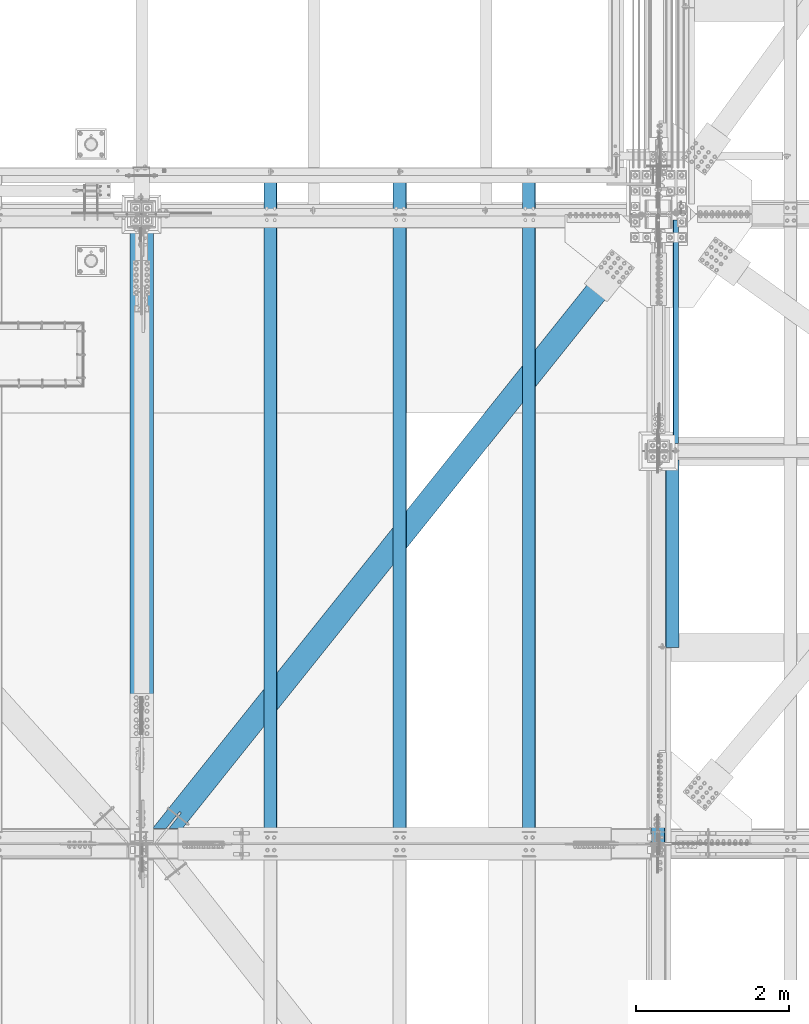
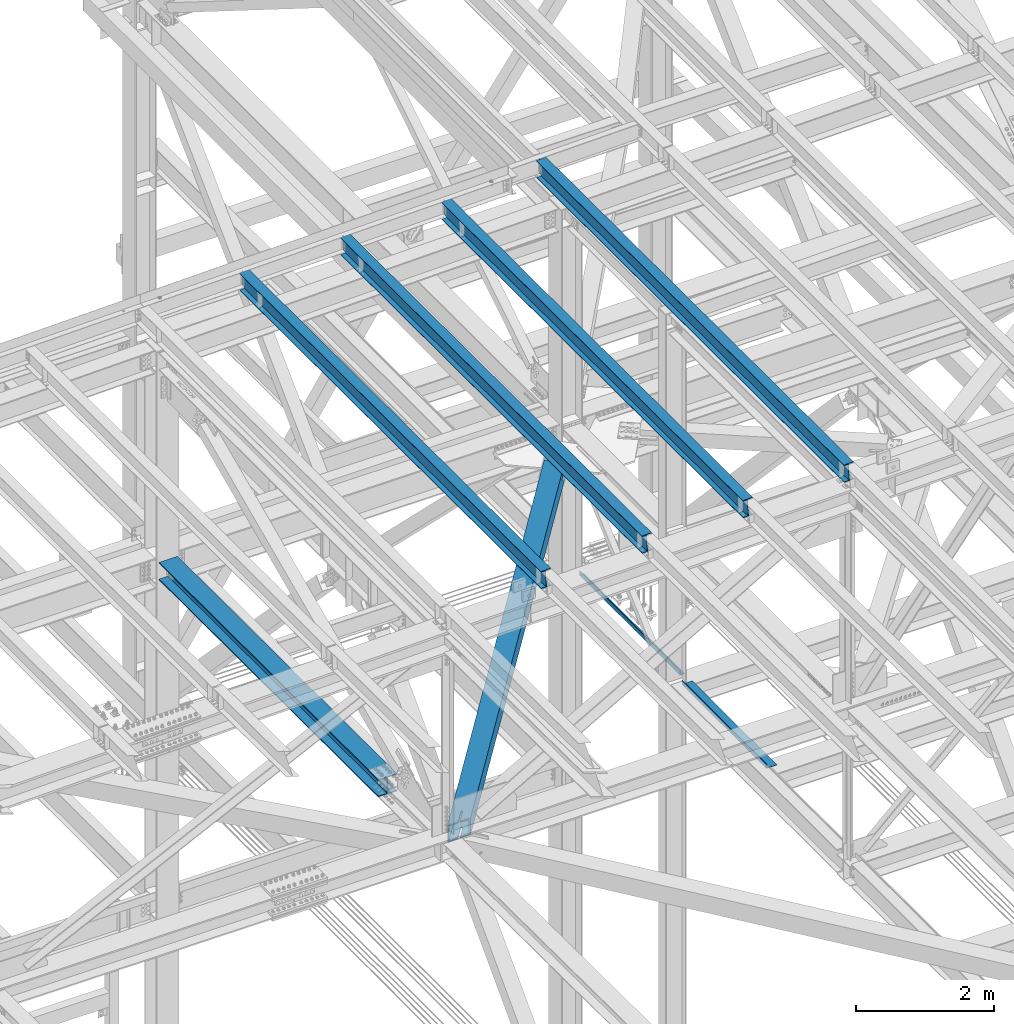
# One storey, part 1929 of 3843: 8 beams, 8 elements without a shape of their own.
"""IFC2X3 building model written with IfcOpenShell, lengths in millimetres."""

from ifc_helpers import new_model, si_unit, frame, origin_with_axes, place, context, subcontext, project, spatial, faceted_brep, material, type_object, element, aggregate, save


model = new_model("IFC2X3")

# Units and contexts
model_context = context("Model", 3, precision=1e-05, world=origin_with_axes())
body_context = subcontext(model_context, "Body", "Model", "MODEL_VIEW")
ifc_project = project(units=[si_unit("LENGTHUNIT", "METRE", prefix="MILLI"), si_unit("AREAUNIT", "SQUARE_METRE"), si_unit("VOLUMEUNIT", "CUBIC_METRE"), si_unit("MASSUNIT", "GRAM", prefix="KILO"), si_unit("TIMEUNIT", "SECOND"), si_unit("PLANEANGLEUNIT", "RADIAN"), si_unit("SOLIDANGLEUNIT", "STERADIAN"), si_unit("THERMODYNAMICTEMPERATUREUNIT", "DEGREE_CELSIUS"), si_unit("LUMINOUSINTENSITYUNIT", "LUMEN")], contexts=[model_context])

# Site, building, storey
site_placement = place(None, origin_with_axes())
site = spatial("IfcSite", under=ifc_project, at=site_placement, CompositionType="ELEMENT")
building_placement = place(site_placement, origin_with_axes())
building = spatial("IfcBuilding", under=site, at=building_placement, Name="Undefined", CompositionType="ELEMENT")
storey_placement = place(building_placement, origin_with_axes())
storey = spatial("IfcBuildingStorey", under=building, at=storey_placement, Name="Undefined", CompositionType="ELEMENT", Elevation=0.0)

# Assembly, beam
assembly_1_placement = place(storey_placement, origin_with_axes())
assembly_1 = element("IfcElementAssembly", 1, at=assembly_1_placement, inside=storey, Name="BEAM", AssemblyPlace="NOTDEFINED", PredefinedType="RIGID_FRAME")
ifc_material_1 = material(Name="STEEL/A992")
beam_type_1 = type_object("IfcBeamType", Name="W12X26", PredefinedType="NOTDEFINED")
beam_1_placement = place(assembly_1_placement, frame((75320.4092623347, 83985.4146285505, 46411.5735238448), z_axis=(-0.021152098282546, 0.00202235899982043, 0.99977422391374), x_axis=(0.0, 0.999997954113713, -0.00202281200022976)))
beam_1 = element("IfcBeam", 2, at=beam_1_placement, type_object=beam_type_1, material=ifc_material_1, Name="BEAM", ObjectType="W12X26", context=body_context, shape_type="Brep", body=[
    faceted_brep([(8748.73407185475, -3.1749999998865, -146.049999975927), (8748.73407185473, -82.5500000003231, -146.049999975927), (8748.73407185476, -82.5500000002648, -155.57499997595), (8748.73407185478, 82.5500000006286, -155.57499997595), (8748.73407185476, 82.550000000585, -146.049999975934), (8748.73407185475, 3.17500000014843, -146.049999975927), (8748.7340718543, 3.17500000013388, -142.874999314576), (8748.73407185433, -3.1749999998865, -142.874999314554), (8749.70080177688, 3.17500000011933, -138.014919796507), (8749.70080177693, -3.1749999999156, -138.014919796478), (8752.45381567739, 3.17500000011933, -133.894743328317), (8752.45381567742, -3.17499999993015, -133.894743328288), (8756.5739921456, 3.17500000009022, -131.141729427814), (8756.5739921456, -3.17499999993015, -131.141729427778), (8761.43407166368, 3.17500000007567, -130.174999505201), (8761.43407166369, -3.1749999999447, -130.174999505172), (8818.52903538667, -3.17499999995925, -130.174999504052), (8818.52930708288, 3.17500000009022, -130.174999504023), (12.090166436974, 3.17499999934807, 146.050000000345), (12.0935626394639, 82.5499999997701, 146.050000000352), (8748.73407185427, 82.5499999992608, 146.050000024705), (8748.73407185427, 3.17499999882421, 146.050000024705), (12.6964939507743, -82.5499999997555, -155.575000000295), (12.6772309377411, -82.5499999997992, -146.050000000272), (12.6806271402311, -3.17499999937718, -146.050000000272), (12.0898947407695, -3.1750000007014, 146.050000000352), (12.0864985383087, -82.5500000011234, 146.050000000359), (12.0672355252755, -82.5500000011816, 155.575000000375), (12.0742996264307, 82.5499999997264, 155.575000000368), (12.6808988364355, 3.1750000006723, -146.050000000272), (12.6842950389109, 82.5500000010943, -146.050000000272), (12.7035580519441, 82.5500000011525, -155.575000000295), (8748.73407185425, -3.17500000121072, 146.050000024705), (8748.73407185425, -82.5500000016327, 146.050000024705), (8748.73407185423, -82.5500000016909, 155.575000024728), (8748.73407185423, 82.5499999992171, 155.575000024721), (8748.73407185383, -3.17500000121072, 142.875000305459), (8748.73407185382, 3.17499999882421, 142.87500030543), (8749.70080177645, -3.17500000118162, 138.014920787384), (8749.7008017764, 3.17499999886786, 138.014920787355), (8752.45381567696, -3.17500000115251, 133.894744319208), (8752.45381567693, 3.17499999888241, 133.894744319179), (8756.57399214516, -3.17500000115251, 131.141730418734), (8756.57399214513, 3.17499999889696, 131.141730418698), (8761.43407166327, -3.17500000115251, 130.175000496143), (8761.43407166324, 3.17499999888241, 130.175000496121), (8818.00251303065, -3.17500000113796, 130.175000497125), (8818.00278472685, 3.17499999889696, 130.175000497155), (8818.49469513241, 3.17500000000291, -113.06039610249), (8818.02833904634, 3.17499999895517, 117.539132327023)], [[[0, 1, 2, 3, 4, 5, 6, 7]], [[7, 6, 8, 9]], [[9, 8, 10, 11]], [[11, 10, 12, 13]], [[13, 12, 14, 15]], [[16, 15, 14, 17]], [[18, 19, 20, 21]], [[22, 23, 24, 25, 26, 27, 28, 19, 18, 29, 30, 31]], [[26, 25, 32, 33]], [[27, 26, 33, 34]], [[28, 27, 34, 35]], [[19, 28, 35, 20]], [[34, 33, 32, 36, 37, 21, 20, 35]], [[38, 39, 37, 36]], [[40, 41, 39, 38]], [[42, 43, 41, 40]], [[44, 45, 43, 42]], [[46, 47, 45, 44]], [[48, 49, 47, 46, 16, 17]], [[12, 10, 8, 6, 5, 29, 18, 21, 37, 39, 41, 43, 45, 47, 49, 48, 17, 14]], [[30, 29, 5, 4]], [[31, 30, 4, 3]], [[22, 31, 3, 2]], [[23, 22, 2, 1]], [[24, 23, 1, 0]], [[46, 44, 42, 40, 38, 36, 32, 25, 24, 0, 7, 9, 11, 13, 15, 16]]]),
])
aggregate(assembly_1, [beam_1])

assembly_2_placement = place(storey_placement, origin_with_axes())
assembly_2 = element("IfcElementAssembly", 3, at=assembly_2_placement, inside=storey, Name="BEAM", AssemblyPlace="NOTDEFINED", PredefinedType="RIGID_FRAME")
beam_2_placement = place(assembly_2_placement, frame((77009.5092627052, 83985.4379680159, 46448.9393835819), z_axis=(-0.021152097941289, 0.00217238000044017, 0.999773909200383), x_axis=(0.0, 0.999997639323885, -0.00217286600070357)))
beam_2 = element("IfcBeam", 4, at=beam_2_placement, type_object=beam_type_1, material=ifc_material_1, Name="BEAM", ObjectType="W12X26", context=body_context, shape_type="Brep", body=[
    faceted_brep([(8924.94998399743, -3.17500000086147, -146.049999988769), (8924.94998399742, -82.5500000013126, -146.049999988587), (8924.94998399743, -82.5500000013417, -155.574999988588), (8924.94998399743, 82.5499999995955, -155.574999988974), (8924.94998399742, 82.5499999996246, -146.049999988973), (8924.94998399742, 3.17499999917345, -146.049999988783), (8924.94998399605, 3.17499999920256, -142.874999508247), (8924.94998399614, -3.17500000084692, -142.87499950824), (8925.91671391873, 3.17499999921711, -138.014919990193), (8925.91671391881, -3.17500000081782, -138.014919990186), (8928.66972781932, 3.17499999923166, -133.894743522018), (8928.66972781942, -3.17500000080327, -133.894743522011), (8932.78990428759, 3.17499999924621, -131.141729621493), (8932.78990428768, -3.17500000078871, -131.1417296215), (8937.64998380574, 3.17499999924621, -130.174999698858), (8937.64998380582, -3.17500000078871, -130.174999698858), (8975.69115626781, 3.17499999923166, -130.174999697447), (8975.69086441689, -3.17500000078871, -130.174999697425), (12.0449302655761, 3.17500000062864, 146.050000000061), (12.048578402173, 82.5500000010652, 146.049999999879), (8924.94998399782, 82.5500000008324, 146.050000011121), (8924.94998399782, 3.17500000039581, 146.05000001131), (12.6962628250476, -82.5500000003522, -155.574999999924), (12.675543931924, -82.5500000010652, -146.049999999828), (12.6791920685064, -3.17500000061409, -146.050000000017), (12.0446384146489, -3.17499999942083, 146.050000000076), (12.0409902780666, -82.5499999998574, 146.050000000265), (12.0202983110794, -82.5499999998283, 155.575000000274), (12.0278864352003, 82.5500000010943, 155.574999999873), (12.6794839194336, 3.17499999940628, -146.050000000032), (12.6831320560304, 82.5499999998574, -146.050000000214), (12.7037963889888, 82.550000000585, -155.57500000039), (8924.94998399784, -3.17499999965366, 146.050000011324), (8924.94998399782, -82.5500000000902, 146.050000011513), (8924.94998399782, -82.5500000000611, 155.575000011515), (8924.94998399782, 82.5500000008615, 155.575000011129), (8924.94998399614, -3.17499999966822, 142.875000110747), (8924.94998399603, 3.17500000036671, 142.875000110747), (8925.91671391868, -3.17499999969732, 138.014920592701), (8925.91671391857, 3.1750000003376, 138.014920592701), (8928.66972781914, -3.17499999971187, 133.894744124562), (8928.66972781904, 3.1750000003376, 133.894744124569), (8932.78990428733, -3.17499999972642, 131.141730224117), (8932.78990428725, 3.17500000032305, 131.141730224117), (8937.64998380546, -3.17499999971187, 130.175000301584), (8937.64998380536, 3.1750000003085, 130.175000301577), (8975.12557583718, 3.1750000003085, 130.175000301024), (8975.12528398627, -3.17499999972642, 130.175000301046)], [[[0, 1, 2, 3, 4, 5, 6, 7]], [[7, 6, 8, 9]], [[9, 8, 10, 11]], [[11, 10, 12, 13]], [[13, 12, 14, 15]], [[16, 17, 15, 14]], [[18, 19, 20, 21]], [[22, 23, 24, 25, 26, 27, 28, 19, 18, 29, 30, 31]], [[26, 25, 32, 33]], [[27, 26, 33, 34]], [[28, 27, 34, 35]], [[19, 28, 35, 20]], [[34, 33, 32, 36, 37, 21, 20, 35]], [[38, 39, 37, 36]], [[40, 41, 39, 38]], [[42, 43, 41, 40]], [[44, 45, 43, 42]], [[46, 45, 44, 47]], [[12, 10, 8, 6, 5, 29, 18, 21, 37, 39, 41, 43, 45, 46, 16, 14]], [[30, 29, 5, 4]], [[31, 30, 4, 3]], [[22, 31, 3, 2]], [[23, 22, 2, 1]], [[24, 23, 1, 0]], [[47, 44, 42, 40, 38, 36, 32, 25, 24, 0, 7, 9, 11, 13, 15, 17]], [[46, 47, 17, 16]]]),
])
aggregate(assembly_2, [beam_2])

assembly_3_placement = place(storey_placement, origin_with_axes())
assembly_3 = element("IfcElementAssembly", 5, at=assembly_3_placement, inside=storey, Name="BEAM", AssemblyPlace="NOTDEFINED", PredefinedType="RIGID_FRAME")
beam_3_placement = place(assembly_3_placement, frame((73631.3092623541, 83985.4146285505, 46375.8375062073), z_axis=(-0.021152098282546, 0.00202235899982043, 0.99977422391374), x_axis=(0.0, 0.999997954113713, -0.00202281200022976)))
beam_3 = element("IfcBeam", 6, at=beam_3_placement, type_object=beam_type_1, material=ifc_material_1, Name="BEAM", ObjectType="W12X26", context=body_context, shape_type="Brep", body=[
    faceted_brep([(8748.73407185475, -3.1749999998865, -146.049999975927), (8748.73407185473, -82.5500000003231, -146.049999975927), (8748.73407185476, -82.5500000002648, -155.57499997595), (8748.73407185478, 82.5500000006286, -155.57499997595), (8748.73407185476, 82.550000000585, -146.049999975934), (8748.73407185475, 3.17500000014843, -146.049999975927), (8748.7340718543, 3.17500000013388, -142.874999314576), (8748.73407185433, -3.1749999998865, -142.874999314554), (8749.70080177688, 3.17500000011933, -138.014919796507), (8749.70080177693, -3.1749999999156, -138.014919796478), (8752.45381567739, 3.17500000011933, -133.894743328317), (8752.45381567742, -3.17499999993015, -133.894743328288), (8756.5739921456, 3.17500000009022, -131.141729427814), (8756.5739921456, -3.17499999993015, -131.141729427778), (8761.43407166368, 3.17500000007567, -130.174999505201), (8761.43407166369, -3.1749999999447, -130.174999505172), (8818.52903538667, -3.17499999995925, -130.174999504052), (8818.52930708288, 3.17500000009022, -130.174999504023), (12.090166436974, 3.17499999934807, 146.050000000345), (12.0935626394639, 82.5499999997701, 146.050000000352), (8748.73407185427, 82.5499999992608, 146.050000024705), (8748.73407185427, 3.17499999882421, 146.050000024705), (12.6964939507743, -82.5499999997555, -155.575000000295), (12.6772309377411, -82.5499999997992, -146.050000000272), (12.6806271402311, -3.17499999937718, -146.050000000272), (12.0898947407695, -3.1750000007014, 146.050000000352), (12.0864985383087, -82.5500000011234, 146.050000000359), (12.0672355252755, -82.5500000011816, 155.575000000375), (12.0742996264307, 82.5499999997264, 155.575000000368), (12.6808988364355, 3.1750000006723, -146.050000000272), (12.6842950389109, 82.5500000010943, -146.050000000272), (12.7035580519441, 82.5500000011525, -155.575000000295), (8748.73407185425, -3.17500000121072, 146.050000024705), (8748.73407185425, -82.5500000016327, 146.050000024705), (8748.73407185423, -82.5500000016909, 155.575000024728), (8748.73407185423, 82.5499999992171, 155.575000024721), (8748.73407185383, -3.17500000121072, 142.875000305459), (8748.73407185382, 3.17499999882421, 142.87500030543), (8749.70080177645, -3.17500000118162, 138.014920787384), (8749.7008017764, 3.17499999886786, 138.014920787355), (8752.45381567696, -3.17500000115251, 133.894744319208), (8752.45381567693, 3.17499999888241, 133.894744319179), (8756.57399214516, -3.17500000115251, 131.141730418734), (8756.57399214513, 3.17499999889696, 131.141730418698), (8761.43407166327, -3.17500000115251, 130.175000496143), (8761.43407166324, 3.17499999888241, 130.175000496121), (8818.00251303065, -3.17500000113796, 130.175000497125), (8818.00278472685, 3.17499999889696, 130.175000497155), (8818.49469513241, 3.17500000000291, -113.06039610249), (8818.02833904634, 3.17499999895517, 117.539132327023)], [[[0, 1, 2, 3, 4, 5, 6, 7]], [[7, 6, 8, 9]], [[9, 8, 10, 11]], [[11, 10, 12, 13]], [[13, 12, 14, 15]], [[16, 15, 14, 17]], [[18, 19, 20, 21]], [[22, 23, 24, 25, 26, 27, 28, 19, 18, 29, 30, 31]], [[26, 25, 32, 33]], [[27, 26, 33, 34]], [[28, 27, 34, 35]], [[19, 28, 35, 20]], [[34, 33, 32, 36, 37, 21, 20, 35]], [[38, 39, 37, 36]], [[40, 41, 39, 38]], [[42, 43, 41, 40]], [[44, 45, 43, 42]], [[46, 47, 45, 44]], [[48, 49, 47, 46, 16, 17]], [[12, 10, 8, 6, 5, 29, 18, 21, 37, 39, 41, 43, 45, 47, 49, 48, 17, 14]], [[30, 29, 5, 4]], [[31, 30, 4, 3]], [[22, 31, 3, 2]], [[23, 22, 2, 1]], [[24, 23, 1, 0]], [[46, 44, 42, 40, 38, 36, 32, 25, 24, 0, 7, 9, 11, 13, 15, 16]]]),
])
aggregate(assembly_3, [beam_3])

assembly_4_placement = place(storey_placement, origin_with_axes())
assembly_4 = element("IfcElementAssembly", 7, at=assembly_4_placement, inside=storey, Name="BEAM", AssemblyPlace="NOTDEFINED", PredefinedType="RIGID_FRAME")
beam_4_placement = place(assembly_4_placement, frame((71942.2092623527, 83985.4002880633, 46339.2865696143), z_axis=(-0.0211520984278759, 0.00193018200022925, 0.999774406118472), x_axis=(0.0, 0.999998136363054, -0.0019306140007009)))
beam_4 = element("IfcBeam", 8, at=beam_4_placement, type_object=beam_type_1, material=ifc_material_1, Name="BEAM", ObjectType="W12X26", context=body_context, shape_type="Brep", body=[
    faceted_brep([(8748.73230346604, -3.17500000059954, -146.050000011535), (8748.73230346604, -82.5500000010361, -146.050000011783), (8748.73230346608, -82.5500000010798, -155.575000011762), (8748.73230346608, 82.5499999998137, -155.575000011253), (8748.73230346604, 82.5499999998719, -146.050000011273), (8748.73230346604, 3.17499999944994, -146.050000011513), (8748.7323034672, 3.17499999944994, -142.875000107881), (8748.73230346713, -3.17500000058499, -142.875000107953), (8749.69903338971, 3.17499999947904, -138.01492058982), (8749.69903338962, -3.17500000054133, -138.014920589892), (8752.45204729018, 3.17499999950815, -133.894744121666), (8752.45204729009, -3.17500000052678, -133.894744121746), (8756.57222375835, 3.17499999950815, -131.141730221221), (8756.57222375828, -3.17500000049768, -131.141730221294), (8761.43230327648, 3.1749999995227, -130.175000298696), (8761.43230327641, -3.17500000051223, -130.175000298768), (8818.52977568889, -3.17500000049768, -130.175000302348), (8818.5300350014, 3.17499999953725, -130.175000302384), (12.1179610849213, 3.17500000083237, 146.049999999763), (12.121202491544, 82.5500000012544, 146.050000000003), (8748.73230346186, 82.5500000015163, 146.049999988267), (8748.73230346186, 3.1750000010943, 146.049999988019), (12.6966526176693, -82.5500000013417, -155.575000000026), (12.6782675991853, -82.550000001298, -146.050000000047), (12.681509005808, -3.17500000084692, -146.049999999799), (12.1177017724112, -3.17499999920256, 146.049999999734), (12.1144603657885, -82.5499999996246, 146.049999999494), (12.09607534729, -82.5499999995809, 155.57499999948), (12.1028174730745, 82.5500000013271, 155.57499999999), (12.6817683183472, 3.174999999188, -146.049999999777), (12.6850097249699, 82.54999999961, -146.049999999537), (12.7033947434393, 82.5499999995664, -155.574999999517), (8748.73230346187, -3.17499999895517, 146.049999988005), (8748.73230346187, -82.5499999993772, 146.049999987765), (8748.73230346182, -82.549999999319, 155.574999987744), (8748.73230346183, 82.5500000015745, 155.574999988254), (8748.73230346334, -3.17499999896972, 142.874999509229), (8748.73230346342, 3.17500000107975, 142.874999509302), (8749.699033386, -3.17499999899883, 138.014919991248), (8749.69903338609, 3.1750000010361, 138.014919991321), (8752.45204728656, -3.17499999901338, 133.894743523124), (8752.45204728663, 3.17500000100699, 133.894743523197), (8756.57222375473, -3.17499999902793, 131.141729622643), (8756.5722237548, 3.17500000099244, 131.141729622723), (8761.43230327277, -3.17499999902793, 130.174999700008), (8761.43230327284, 3.17500000100699, 130.174999700081), (8818.02725185039, -3.17499999904248, 130.174999698371), (8818.02751116293, 3.17500000100699, 130.174999698334), (8818.49700635455, 3.17499999963911, -113.063357927153), (8818.05190636881, 3.17500000093423, 117.536212512605)], [[[0, 1, 2, 3, 4, 5, 6, 7]], [[7, 6, 8, 9]], [[9, 8, 10, 11]], [[11, 10, 12, 13]], [[13, 12, 14, 15]], [[16, 15, 14, 17]], [[18, 19, 20, 21]], [[22, 23, 24, 25, 26, 27, 28, 19, 18, 29, 30, 31]], [[26, 25, 32, 33]], [[27, 26, 33, 34]], [[28, 27, 34, 35]], [[19, 28, 35, 20]], [[34, 33, 32, 36, 37, 21, 20, 35]], [[38, 39, 37, 36]], [[40, 41, 39, 38]], [[42, 43, 41, 40]], [[44, 45, 43, 42]], [[46, 47, 45, 44]], [[48, 49, 47, 46, 16, 17]], [[12, 10, 8, 6, 5, 29, 18, 21, 37, 39, 41, 43, 45, 47, 49, 48, 17, 14]], [[30, 29, 5, 4]], [[31, 30, 4, 3]], [[22, 31, 3, 2]], [[23, 22, 2, 1]], [[24, 23, 1, 0]], [[46, 44, 42, 40, 38, 36, 32, 25, 24, 0, 7, 9, 11, 13, 15, 16]]]),
])
aggregate(assembly_4, [beam_4])

assembly_5_placement = place(storey_placement, origin_with_axes())
assembly_5 = element("IfcElementAssembly", 9, at=assembly_5_placement, inside=storey, Name="BENT_PLATE", AssemblyPlace="NOTDEFINED", PredefinedType="RIGID_FRAME")
ifc_material_2 = material(Name="STEEL/A36")
beam_type_2 = type_object("IfcBeamType", PredefinedType="NOTDEFINED")
beam_5_placement = place(assembly_5_placement, frame((77276.325, 90678.0, 39627.1750000002), z_axis=(0.0, 1.0, 0.0), x_axis=(-1.0, 0.0, 0.0)))
beam_5 = element("IfcBeam", 10, at=beam_5_placement, type_object=beam_type_2, material=ifc_material_2, Name="BENT_PLATE", context=body_context, shape_type="Brep", body=[
    faceted_brep([(0.0, -3.17500000000291, -1460.5), (0.0, -3.17500000000291, 1460.5), (0.0, 3.17500000000291, 1460.5), (0.0, 3.17500000000291, -1460.5), (69.8500000000204, 3.17500000000291, 1460.5), (69.8500000000204, 3.17500000000291, -1460.5), (76.2000000000116, -3.17500000000291, -1460.5), (76.2000000000116, -3.17500000000291, 1460.5), (69.8500000000931, 73.0250000000015, 1460.5), (69.8500000000931, 73.0250000000015, -1460.5), (76.200000000099, 73.0249999999869, 1460.5), (76.200000000099, 73.0249999999869, -1460.5)], [[[0, 1, 2, 3]], [[3, 2, 4, 5]], [[1, 0, 6, 7]], [[5, 4, 8, 9]], [[4, 2, 1, 7, 10, 8]], [[7, 6, 11, 10]], [[6, 0, 3, 5, 9, 11]], [[10, 11, 9, 8]]]),
])
aggregate(assembly_5, [beam_5])

assembly_6_placement = place(storey_placement, origin_with_axes())
assembly_6 = element("IfcElementAssembly", 11, at=assembly_6_placement, inside=storey, Name="BENT_PLATE", AssemblyPlace="NOTDEFINED", PredefinedType="RIGID_FRAME")
beam_type_3 = type_object("IfcBeamType", PredefinedType="NOTDEFINED")
beam_6_placement = place(assembly_6_placement, frame((77279.5000000004, 87776.05, 39627.1749999995), z_axis=(0.0, 1.0, 0.0), x_axis=(-1.0, 0.0, 0.0)))
beam_6 = element("IfcBeam", 12, at=beam_6_placement, type_object=beam_type_3, material=ifc_material_2, Name="BENT_PLATE", context=body_context, shape_type="Brep", body=[
    faceted_brep([(0.0, -3.17500000000291, -1225.55), (0.0, -3.17500000000291, 1225.55), (0.0, 3.17500000000291, 1225.55), (0.0, 3.17500000000291, -1225.55), (169.862500000338, 3.17500000000291, 1225.55), (169.862500000338, 3.17500000000291, -1225.55), (176.212500000329, -3.17500000000291, -1225.55), (176.212500000329, -3.17500000000291, 1225.55), (169.86250000041, 73.0249999998996, 1225.55), (169.86250000041, 73.0249999998996, -1225.55), (176.212500000416, 73.024999999885, 1225.55), (176.212500000416, 73.024999999885, -1225.55)], [[[0, 1, 2, 3]], [[3, 2, 4, 5]], [[1, 0, 6, 7]], [[5, 4, 8, 9]], [[4, 2, 1, 7, 10, 8]], [[7, 6, 11, 10]], [[6, 0, 3, 5, 9, 11]], [[10, 11, 9, 8]]]),
])
aggregate(assembly_6, [beam_6])

assembly_7_placement = place(storey_placement, origin_with_axes())
assembly_7 = element("IfcElementAssembly", 13, at=assembly_7_placement, inside=storey, Name="BEAM", AssemblyPlace="NOTDEFINED", PredefinedType="RIGID_FRAME")
beam_type_4 = type_object("IfcBeamType", Name="W12X79", PredefinedType="NOTDEFINED")
beam_7_placement = place(assembly_7_placement, frame((70256.399998908, 85661.5000000416, 42259.4988984191), z_axis=(0.0, 0.00197596199957479, 0.999998047785183), x_axis=(0.0, 0.999998047785183, -0.00197596199957261)))
beam_7 = element("IfcBeam", 14, at=beam_7_placement, type_object=beam_type_4, material=ifc_material_1, Name="BEAM", ObjectType="W12X79", context=body_context, shape_type="Brep", body=[
    faceted_brep([(6.34999999578577, -153.987500000003, -138.11249999961), (6.34999999578577, -153.987500000003, -157.162499999562), (6362.40187363836, -153.987500000003, -157.162499985461), (6362.4018736385, -153.987500000003, -138.112499985415), (6.34999999578577, -6.34999999999854, -138.11249999961), (6362.4018736385, -6.35000000000582, -138.112499985415), (6.34999999578577, -6.34999999999854, 138.112499999675), (6362.40187364051, -6.35000000000582, 138.112500015319), (6.34999999578577, -153.987500000003, 138.112499999675), (6362.40187364051, -153.987500000003, 138.112500015319), (6.34999999578577, -153.987500000003, 157.162499999627), (6362.40187364063, -153.987500000003, 157.162500015373), (6.34999999578577, 153.987500000003, 157.162499999627), (6362.40187364063, 153.987500000003, 157.162500015373), (6.34999999578577, 153.987500000003, 138.112499999675), (6362.40187364051, 153.987500000003, 138.112500015319), (6.34999999578577, 6.34999999999854, 138.112499999675), (6362.40187364051, 6.35000000000582, 138.112500015319), (6.34999999578577, 6.34999999999854, -138.11249999961), (6362.4018736385, 6.35000000000582, -138.112499985415), (6.34999999578577, 153.987500000003, -138.11249999961), (6362.4018736385, 153.987500000003, -138.112499985415), (6.34999999578577, 153.987500000003, -157.162499999562), (6362.40187363836, 153.987500000003, -157.162499985461)], [[[0, 1, 2, 3]], [[4, 0, 3, 5]], [[6, 4, 5, 7]], [[8, 6, 7, 9]], [[10, 8, 9, 11]], [[12, 10, 11, 13]], [[14, 12, 13, 15]], [[16, 14, 15, 17]], [[18, 16, 17, 19]], [[20, 18, 19, 21]], [[1, 0, 4, 6, 8, 10, 12, 14, 16, 18, 20, 22]], [[1, 22, 23, 2]], [[19, 17, 15, 13, 11, 9, 7, 5, 3, 2, 23, 21]], [[22, 20, 21, 23]]]),
])
aggregate(assembly_7, [beam_7])

assembly_8_placement = place(storey_placement, origin_with_axes())
assembly_8 = element("IfcElementAssembly", 15, at=assembly_8_placement, inside=storey, AssemblyPlace="NOTDEFINED", PredefinedType="RIGID_FRAME")
ifc_material_3 = material()
beam_type_5 = type_object("IfcBeamType", Name="HSS12X12X3/4", PredefinedType="NOTDEFINED")
beam_8_placement = place(assembly_8_placement, frame((70434.1999995667, 83985.10000053, 42246.55), z_axis=(0.781103955072157, -0.624401002057679, 0.0), x_axis=(0.624401003155509, 0.78110395419457, 0.0)))
beam_8 = element("IfcBeam", 16, at=beam_8_placement, type_object=beam_type_5, material=ifc_material_3, ObjectType="HSS12X12X3/4", context=body_context, shape_type="Brep", body=[
    faceted_brep([(265.468671126146, -152.400000000001, 14.2875000030908), (265.468671126146, -133.349999999999, 14.2875000030908), (516.612150622008, -133.349999999999, 14.2874999980413), (516.612150622008, -152.400000000001, 14.2874999980413), (522.079740307912, -133.349999999999, 13.1999287896615), (522.079740307912, -152.400000000001, 13.1999287896615), (526.714939027981, -133.349999999999, 10.1027880223555), (526.714939027981, -152.400000000001, 10.1027880223555), (529.812079795269, -133.349999999999, 5.46758930226497), (529.812079795269, -152.400000000001, 5.46758930226497), (516.612150622397, -152.400000000001, -14.2874999926571), (516.612150622397, -133.349999999999, -14.2874999926571), (242.626310053987, -133.349999999999, -14.2874999877968), (242.626310053987, -152.400000000001, -14.2874999877968), (522.079740308236, -152.400000000001, -13.199928784481), (522.079740308236, -133.349999999999, -13.199928784481), (526.714939028217, -152.400000000001, -10.1027880173497), (526.714939028217, -133.349999999999, -10.1027880173497), (529.812079795382, -152.400000000001, -5.46758929740463), (529.812079795382, -133.349999999999, -5.46758929740463), (530.899651003598, -152.400000000001, 3.8840516936034e-07), (530.899651003598, -133.349999999999, 3.8840516936034e-07), (265.468671126146, 133.349999999999, 14.2875000030908), (265.468671126146, 152.400000000001, 14.2875000030908), (516.612150622008, 152.400000000001, 14.2874999980413), (516.612150622008, 133.349999999999, 14.2874999980413), (522.079740307912, 152.400000000001, 13.1999287896615), (522.079740307912, 133.349999999999, 13.1999287896615), (526.714939027981, 152.400000000001, 10.1027880223555), (526.714939027981, 133.349999999999, 10.1027880223555), (529.812079795269, 152.400000000001, 5.46758930226497), (529.812079795269, 133.349999999999, 5.46758930226497), (516.612150622397, 133.349999999999, -14.2874999926571), (516.612150622397, 152.400000000001, -14.2874999926571), (242.626310053987, 152.400000000001, -14.2874999877968), (242.626310053987, 133.349999999999, -14.2874999877968), (522.079740308236, 133.349999999999, -13.199928784481), (522.079740308236, 152.400000000001, -13.199928784481), (526.714939028217, 133.349999999999, -10.1027880173497), (526.714939028217, 152.400000000001, -10.1027880173497), (529.812079795382, 133.349999999999, -5.46758929740463), (529.812079795382, 152.400000000001, -5.46758929740463), (530.899651003598, 133.349999999999, 3.8840516936034e-07), (530.899651003598, 152.400000000001, 3.8840516936034e-07), (9475.67688591812, -1.58749999999418, -133.349999984617), (9475.67688591813, -1.58749999999418, -152.399999984649), (9223.26438629343, -1.58749999999418, -152.399999985057), (9223.26438629339, -1.58749999999418, -133.349999985025), (9217.79679660751, -0.499928791708953, -152.399999985057), (9217.79679660748, -0.499928791708953, -133.349999985032), (9213.16159788745, 2.59721197553154, -152.399999985078), (9213.16159788742, 2.59721197553154, -133.349999985039), (9210.06445712018, 7.23241069557844, -152.399999985071), (9210.06445712014, 7.23241069557844, -133.349999985054), (9208.97688591191, 12.6999996185332, -152.399999985078), (9208.97688591186, 12.6999996185332, -133.349999985054), (9210.06445712018, 18.1675893044303, -152.399999985071), (9210.06445712014, 18.1675893044303, -133.349999985054), (9213.16159788745, 22.8027880244772, -152.399999985078), (9213.16159788742, 22.8027880244772, -133.349999985039), (9217.79679660751, 25.8999287917177, -152.399999985057), (9217.79679660748, 25.8999287917177, -133.349999985032), (9223.26438629343, 26.9875000000029, -152.399999985057), (9223.26438629339, 26.9875000000029, -133.349999985025), (9475.67688591812, 26.9875000000029, -133.349999984617), (9475.67688591813, 26.9875000000029, -152.399999984649), (9475.6768728417, 133.349999999999, 133.349999938859), (9475.67687284442, 133.349999999999, -133.350000060527), (9475.67687284461, 152.400000000001, -152.400000060486), (9475.6768728415, 152.400000000001, 152.399999938803), (9475.67688591812, 26.9875000000029, 152.400000015885), (9475.67688591812, 26.9875000000029, 133.350000015853), (9475.67687284442, -133.349999999999, -133.350000060527), (147.449805546054, 133.349999999999, -133.350000000632), (147.449805546054, -133.349999999999, -133.350000000632), (360.645175619266, -133.349999999999, 133.349999997401), (9475.6768728417, -133.349999999999, 133.349999938859), (9223.26438629297, 26.9875000000029, 133.350000015438), (9217.79679660704, 25.8999287917177, 133.350000015424), (9213.16159788697, 22.8027880244772, 133.350000015409), (9210.0644571197, 18.1675893044303, 133.350000015416), (9208.97688591141, 12.6999996185332, 133.350000015409), (9210.0644571197, 7.23241069557844, 133.350000015416), (9213.16159788697, 2.59721197553154, 133.350000015409), (9217.79679660704, -0.499928791708953, 133.350000015424), (9223.26438629297, -1.58749999999418, 133.350000015438), (9475.67688591812, -1.58749999999418, 133.350000015853), (360.645175619266, 133.349999999999, 133.349999997401), (9223.26438629294, 26.9875000000029, 152.400000015463), (9217.79679660698, 25.8999287917177, 152.400000015456), (9213.16159788692, 22.8027880244772, 152.400000015448), (9210.06445711966, 18.1675893044303, 152.400000015448), (9208.97688591138, 12.6999996185332, 152.400000015448), (9210.06445711966, 7.23241069557844, 152.400000015448), (9213.16159788692, 2.59721197553154, 152.400000015448), (9217.79679660698, -0.499928791708953, 152.400000015456), (9223.26438629294, -1.58749999999418, 152.400000015463), (9475.67688591812, -1.58749999999418, 152.400000015885), (9475.6768728415, -152.400000000001, 152.399999938803), (9475.67687284461, -152.400000000001, -152.400000060486), (132.221564826541, -152.400000000001, -152.400000000489), (132.221564826541, 152.400000000001, -152.400000000489), (375.873416338774, 152.400000000001, 152.399999997244), (375.873416338774, -152.400000000001, 152.399999997244)], [[[0, 1, 2, 3]], [[3, 2, 4, 5]], [[5, 4, 6, 7]], [[7, 6, 8, 9]], [[10, 11, 12, 13]], [[14, 15, 11, 10]], [[16, 17, 15, 14]], [[18, 19, 17, 16]], [[20, 21, 19, 18]], [[9, 8, 21, 20]], [[22, 23, 24, 25]], [[25, 24, 26, 27]], [[27, 26, 28, 29]], [[29, 28, 30, 31]], [[32, 33, 34, 35]], [[36, 37, 33, 32]], [[38, 39, 37, 36]], [[40, 41, 39, 38]], [[42, 43, 41, 40]], [[31, 30, 43, 42]], [[44, 45, 46, 47]], [[47, 46, 48, 49]], [[49, 48, 50, 51]], [[51, 50, 52, 53]], [[53, 52, 54, 55]], [[55, 54, 56, 57]], [[57, 56, 58, 59]], [[59, 58, 60, 61]], [[61, 60, 62, 63]], [[64, 63, 62, 65]], [[66, 67, 64, 65, 68, 69, 70, 71]], [[72, 44, 47, 49, 51, 53, 55, 57, 59, 61, 63, 64, 67, 73, 74]], [[6, 4, 2, 1, 75, 76, 72, 74, 12, 11, 15, 17, 19, 21, 8]], [[66, 71, 77, 78, 79, 80, 81, 82, 83, 84, 85, 86, 76, 75, 87]], [[70, 88, 77, 71]], [[89, 78, 77, 88]], [[90, 79, 78, 89]], [[91, 80, 79, 90]], [[92, 81, 80, 91]], [[93, 82, 81, 92]], [[94, 83, 82, 93]], [[95, 84, 83, 94]], [[96, 85, 84, 95]], [[97, 86, 85, 96]], [[98, 99, 45, 44, 72, 76, 86, 97]], [[68, 65, 62, 60, 58, 56, 54, 52, 50, 48, 46, 45, 99, 100, 101]], [[74, 73, 35, 34, 101, 100, 13, 12]], [[28, 26, 24, 23, 102, 69, 68, 101, 34, 33, 37, 39, 41, 43, 30]], [[98, 97, 96, 95, 94, 93, 92, 91, 90, 89, 88, 70, 69, 102, 103]], [[16, 14, 10, 13, 100, 99, 98, 103, 0, 3, 5, 7, 9, 20, 18]], [[103, 102, 23, 22, 87, 75, 1, 0]], [[38, 36, 32, 35, 73, 67, 66, 87, 22, 25, 27, 29, 31, 42, 40]]]),
])
aggregate(assembly_8, [beam_8])

save(model, "model.ifc")
